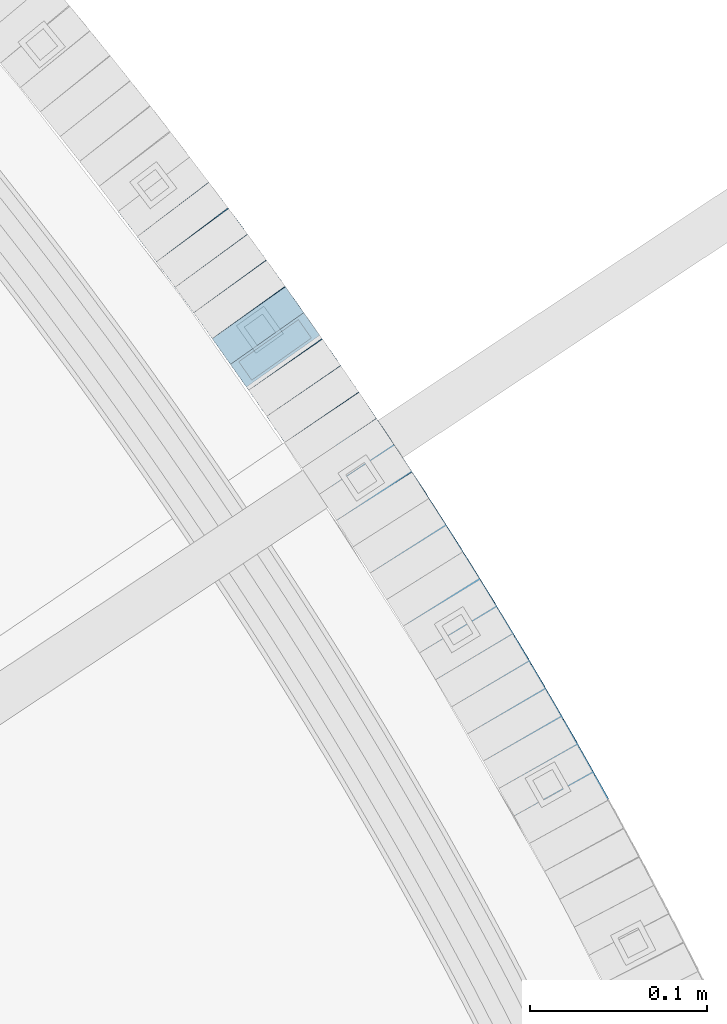
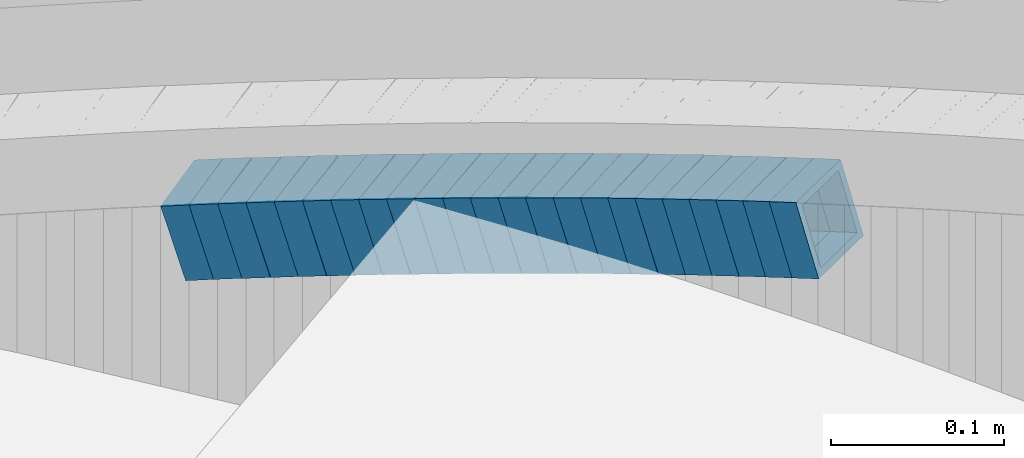
# One storey, part 808 of 975: 23 beams.
"""IFC2X3 building model written with IfcOpenShell, lengths in millimetres."""

from ifc_helpers import new_model, si_unit, frame, origin_with_axes, place, context, subcontext, project, spatial, faceted_brep, material, type_object, element, save


model = new_model("IFC2X3")

# Units and contexts
model_context = context("Model", 3, precision=1e-05, world=origin_with_axes())
body_context = subcontext(model_context, "Body", "Model", "MODEL_VIEW")
ifc_project = project(units=[si_unit("LENGTHUNIT", "METRE", prefix="MILLI"), si_unit("AREAUNIT", "SQUARE_METRE"), si_unit("VOLUMEUNIT", "CUBIC_METRE"), si_unit("MASSUNIT", "GRAM", prefix="KILO"), si_unit("TIMEUNIT", "SECOND"), si_unit("PLANEANGLEUNIT", "RADIAN"), si_unit("SOLIDANGLEUNIT", "STERADIAN"), si_unit("THERMODYNAMICTEMPERATUREUNIT", "DEGREE_CELSIUS"), si_unit("LUMINOUSINTENSITYUNIT", "LUMEN")], contexts=[model_context])

# Site, building, storey
site_placement = place(None, origin_with_axes())
site = spatial("IfcSite", under=ifc_project, at=site_placement, CompositionType="ELEMENT")
building_placement = place(site_placement, origin_with_axes())
building = spatial("IfcBuilding", under=site, at=building_placement, Name="Undefined", CompositionType="ELEMENT")
storey_placement = place(building_placement, origin_with_axes())
storey = spatial("IfcBuildingStorey", under=building, at=storey_placement, Name="Undefined", CompositionType="ELEMENT", Elevation=0.0)

# Beams
ifc_material = material()
beam_type = type_object("IfcBeamType", Name="HSS2X2X.188_TUBES", PredefinedType="NOTDEFINED")
beam_1_placement = place(storey_placement, frame((37245.682915631, 4794.72822653761, 2011.89610703231), z_axis=(-0.870978467775846, -0.491321186873556, 0.0), x_axis=(-0.468184465966171, 0.829963370939734, -0.303255846977968)))
element("IfcBeam", 1, at=beam_1_placement, inside=storey, type_object=beam_type, material=ifc_material, Name="WALL", ObjectType="HSS2X2X.188_TUBES", context=body_context, shape_type="Brep", body=[
    faceted_brep([(0.0, 20.6374999999753, -20.6375000000298), (0.0, -20.6375000000153, -20.6375000000153), (18.8047866246379, -20.6374999999916, -20.6375000000298), (18.8047866247143, 20.6374999999844, -20.6374999999643), (0.0, -20.6374999999825, 20.6375000000335), (18.8047866247107, -20.6375000000189, 20.6375000000407), (0.0, 20.6375000000116, 20.6375000000189), (18.8047866247907, 20.6374999999589, 20.6375000001026), (0.0, 25.3999999999724, -25.4000000000342), (0.0, 25.400000000016, 25.4000000000196), (18.8047866248016, 25.3999999999542, 25.4000000001142), (18.8047866247143, 25.3999999999851, -25.3999999999651), (0.0, -25.399999999976, 25.4000000000378), (18.8047866247107, -25.4000000000196, 25.4000000000415), (0.0, -25.400000000016, -25.4000000000196), (18.8047866246197, -25.3999999999887, -25.4000000000378)], [[[0, 1, 2, 3]], [[1, 4, 5, 2]], [[4, 6, 7, 5]], [[6, 0, 3, 7]], [[8, 9, 10, 11]], [[9, 12, 13, 10]], [[12, 14, 15, 13]], [[14, 8, 11, 15]], [[13, 15, 11, 10], [5, 7, 3, 2]], [[14, 12, 9, 8], [6, 4, 1, 0]]]),
])
beam_2_placement = place(storey_placement, frame((37236.8837602042, 4810.36994006417, 2006.20699476173), z_axis=(-0.869620813888914, -0.493720204216096, 7.76358319853899e-11), x_axis=(-0.470258877823187, 0.828296886688576, -0.304599499885487)))
element("IfcBeam", 2, at=beam_2_placement, inside=storey, type_object=beam_type, material=ifc_material, Name="WALL", ObjectType="HSS2X2X.188_TUBES", context=body_context, shape_type="Brep", body=[
    faceted_brep([(0.0, 20.6374999999753, -20.6375000000298), (0.0, -20.6375000000153, -20.6375000000153), (18.7112265765609, -20.6375000000062, -20.6374999999862), (18.7112265765645, 20.6374999999898, -20.6374999999789), (0.0, -20.6374999999825, 20.6375000000335), (18.7112265765209, -20.6374999999916, 20.6374999999607), (0.0, 20.6375000000116, 20.6375000000189), (18.7112265765245, 20.6375000000025, 20.6374999999716), (0.0, 25.3999999999724, -25.4000000000342), (0.0, 25.400000000016, 25.4000000000196), (18.7112265765172, 25.4000000000051, 25.3999999999614), (18.7112265765718, 25.3999999999887, -25.3999999999724), (0.0, -25.399999999976, 25.4000000000378), (18.7112265765136, -25.3999999999905, 25.3999999999542), (0.0, -25.400000000016, -25.4000000000196), (18.7112265765682, -25.4000000000069, -25.3999999999796)], [[[0, 1, 2, 3]], [[1, 4, 5, 2]], [[4, 6, 7, 5]], [[6, 0, 3, 7]], [[8, 9, 10, 11]], [[9, 12, 13, 10]], [[12, 14, 15, 13]], [[14, 8, 11, 15]], [[13, 15, 11, 10], [5, 7, 3, 2]], [[14, 12, 9, 8], [6, 4, 1, 0]]]),
])
beam_3_placement = place(storey_placement, frame((37228.0679755835, 4826.04901976158, 2000.53379788155), z_axis=(-0.864788946395478, -0.502135517756113, 3.0982323551143e-10), x_axis=(-0.477744426089833, 0.82278206615493, -0.307879741057965)))
element("IfcBeam", 3, at=beam_3_placement, inside=storey, type_object=beam_type, material=ifc_material, Name="WALL", ObjectType="HSS2X2X.188_TUBES", context=body_context, shape_type="Brep", body=[
    faceted_brep([(0.0, 20.6374999999753, -20.6375000000298), (0.0, -20.6375000000153, -20.6375000000153), (18.8433011969464, -20.6374999999898, -20.6375000000226), (18.8433011969719, 20.6375000000007, -20.6374999999862), (0.0, -20.6374999999825, 20.6375000000335), (18.8433011969828, -20.6375000000044, 20.6375000000189), (0.0, 20.6375000000116, 20.6375000000189), (18.8433011970155, 20.6374999999862, 20.6375000000517), (0.0, 25.3999999999724, -25.4000000000342), (0.0, 25.400000000016, 25.4000000000196), (18.8433011970228, 25.3999999999833, 25.4000000000597), (18.8433011969719, 25.4000000000015, -25.3999999999869), (0.0, -25.399999999976, 25.4000000000378), (18.8433011969864, -25.4000000000051, 25.4000000000196), (0.0, -25.400000000016, -25.4000000000196), (18.8433011969391, -25.3999999999869, -25.4000000000269)], [[[0, 1, 2, 3]], [[1, 4, 5, 2]], [[4, 6, 7, 5]], [[6, 0, 3, 7]], [[8, 9, 10, 11]], [[9, 12, 13, 10]], [[12, 14, 15, 13]], [[14, 8, 11, 15]], [[13, 15, 11, 10], [5, 7, 3, 2]], [[14, 12, 9, 8], [6, 4, 1, 0]]]),
])
beam_4_placement = place(storey_placement, frame((37219.0063494716, 4841.69829916659, 1994.70533664478), z_axis=(-0.863371944222782, -0.504568019130199, 0.0), x_axis=(-0.480624148905367, 0.822401320838031, -0.304395293940056)))
element("IfcBeam", 4, at=beam_4_placement, inside=storey, type_object=beam_type, material=ifc_material, Name="WALL", ObjectType="HSS2X2X.188_TUBES", context=body_context, shape_type="Brep", body=[
    faceted_brep([(0.0, 20.6374999999753, -20.6375000000298), (0.0, -20.6375000000153, -20.6375000000153), (18.7347271129966, -20.6375000000116, -20.6375000000262), (18.7347271130257, 20.6374999999989, -20.6374999999935), (0.0, -20.6374999999825, 20.6375000000335), (18.7347271129947, -20.6375000000116, 20.6374999999607), (0.0, 20.6375000000116, 20.6375000000189), (18.7347271130147, 20.6375000000007, 20.6374999999898), (0.0, 25.3999999999724, -25.4000000000342), (0.0, 25.400000000016, 25.4000000000196), (18.7347271130166, 25.4000000000015, 25.3999999999905), (18.7347271130257, 25.3999999999996, -25.3999999999869), (0.0, -25.399999999976, 25.4000000000378), (18.7347271129875, -25.4000000000106, 25.3999999999505), (0.0, -25.400000000016, -25.4000000000196), (18.7347271130002, -25.4000000000124, -25.4000000000233)], [[[0, 1, 2, 3]], [[1, 4, 5, 2]], [[4, 6, 7, 5]], [[6, 0, 3, 7]], [[8, 9, 10, 11]], [[9, 12, 13, 10]], [[12, 14, 15, 13]], [[14, 8, 11, 15]], [[13, 15, 11, 10], [5, 7, 3, 2]], [[14, 12, 9, 8], [6, 4, 1, 0]]]),
])
beam_5_placement = place(storey_placement, frame((37209.96551949, 4857.28463881204, 1989.0097921174), z_axis=(-0.859469187145032, -0.511187554962226, -3.09330062009393e-10), x_axis=(-0.486839890903448, 0.81853300483774, -0.304943667939537)))
element("IfcBeam", 5, at=beam_5_placement, inside=storey, type_object=beam_type, material=ifc_material, Name="WALL", ObjectType="HSS2X2X.188_TUBES", context=body_context, shape_type="Brep", body=[
    faceted_brep([(0.0, 20.6374999999753, -20.6375000000298), (0.0, -20.6375000000153, -20.6375000000153), (18.6895692834223, -20.637499999988, -20.6374999999862), (18.6895692834369, 20.6374999999953, -20.6374999999534), (0.0, -20.6374999999825, 20.6375000000335), (18.6895692833914, -20.637499999988, 20.6374999999789), (0.0, 20.6375000000116, 20.6375000000189), (18.6895692834078, 20.6374999999953, 20.637500000008), (0.0, 25.3999999999724, -25.4000000000342), (0.0, 25.400000000016, 25.4000000000196), (18.6895692834059, 25.3999999999924, 25.4000000000087), (18.6895692834423, 25.3999999999942, -25.3999999999432), (0.0, -25.399999999976, 25.4000000000378), (18.6895692833878, -25.3999999999869, 25.3999999999687), (0.0, -25.400000000016, -25.4000000000196), (18.6895692834241, -25.3999999999869, -25.3999999999833)], [[[0, 1, 2, 3]], [[1, 4, 5, 2]], [[4, 6, 7, 5]], [[6, 0, 3, 7]], [[8, 9, 10, 11]], [[9, 12, 13, 10]], [[12, 14, 15, 13]], [[14, 8, 11, 15]], [[13, 15, 11, 10], [5, 7, 3, 2]], [[14, 12, 9, 8], [6, 4, 1, 0]]]),
])
beam_6_placement = place(storey_placement, frame((37200.8461637376, 4872.76189874815, 1983.33619127694), z_axis=(-0.854521941415858, -0.519415297848334, -1.11954477688414e-10), x_axis=(-0.494135901994879, 0.812933257991443, -0.308170777996756)))
element("IfcBeam", 6, at=beam_6_placement, inside=storey, type_object=beam_type, material=ifc_material, Name="WALL", ObjectType="HSS2X2X.188_TUBES", context=body_context, shape_type="Brep", body=[
    faceted_brep([(0.0, 20.6374999999753, -20.6375000000298), (0.0, -20.6375000000153, -20.6375000000153), (18.8225928075335, -20.6374999999935, -20.6375000000298), (18.8225928075699, 20.6374999999898, -20.6374999999825), (0.0, -20.6374999999825, 20.6375000000335), (18.8225928075772, -20.637500000008, 20.6375000000226), (0.0, 20.6375000000116, 20.6375000000189), (18.8225928076135, 20.6374999999753, 20.6375000000698), (0.0, 25.3999999999724, -25.4000000000342), (0.0, 25.400000000016, 25.4000000000196), (18.8225928076281, 25.3999999999705, 25.4000000000815), (18.8225928075663, 25.3999999999905, -25.3999999999796), (0.0, -25.399999999976, 25.4000000000378), (18.8225928075808, -25.4000000000087, 25.4000000000233), (0.0, -25.400000000016, -25.4000000000196), (18.8225928075226, -25.3999999999905, -25.4000000000378)], [[[0, 1, 2, 3]], [[1, 4, 5, 2]], [[4, 6, 7, 5]], [[6, 0, 3, 7]], [[8, 9, 10, 11]], [[9, 12, 13, 10]], [[12, 14, 15, 13]], [[14, 8, 11, 15]], [[13, 15, 11, 10], [5, 7, 3, 2]], [[14, 12, 9, 8], [6, 4, 1, 0]]]),
])
beam_7_placement = place(storey_placement, frame((37191.4825666275, 4888.16652625196, 1977.49687076093), z_axis=(-0.854521941415858, -0.519415297848334, -1.11954477688414e-10), x_axis=(-0.494939984048736, 0.814256102080019, -0.303350313029823)))
element("IfcBeam", 7, at=beam_7_placement, inside=storey, type_object=beam_type, material=ifc_material, Name="WALL", ObjectType="HSS2X2X.188_TUBES", context=body_context, shape_type="Brep", body=[
    faceted_brep([(0.0, 20.6374999999753, -20.6375000000298), (0.0, -20.6375000000153, -20.6375000000153), (18.7853666454903, -20.6375000000535, -20.6375000000326), (18.785366645363, 20.6374999999862, -20.6375000000044), (0.0, -20.6374999999825, 20.6375000000335), (18.785366645352, -20.6375000000007, 20.6374999999989), (0.0, 20.6375000000116, 20.6375000000189), (18.7853666453102, 20.6375000000025, 20.6374999999753), (0.0, 25.3999999999724, -25.4000000000342), (0.0, 25.400000000016, 25.4000000000196), (18.7853666452065, 25.4000000000451, 25.4000000000351), (18.7853666453739, 25.3999999999833, -25.400000000006), (0.0, -25.399999999976, 25.4000000000378), (18.7853666497213, -25.399999993424, 25.3999999995158), (0.0, -25.400000000016, -25.4000000000196), (18.7853666455194, -25.4000000000633, -25.4000000000406)], [[[0, 1, 2, 3]], [[1, 4, 5, 2]], [[4, 6, 7, 5]], [[6, 0, 3, 7]], [[8, 9, 10, 11]], [[9, 12, 13, 10]], [[12, 14, 15, 13]], [[14, 8, 11, 15]], [[13, 15, 11, 10], [5, 7, 3, 2]], [[14, 12, 9, 8], [6, 4, 1, 0]]]),
])
beam_8_placement = place(storey_placement, frame((37182.0943144017, 4903.79217576543, 1971.79440949912), z_axis=(-0.847998304196438, -0.52999893969702, 2.2196581994649e-10), x_axis=(-0.5050762719802, 0.80812203596829, -0.303045762988115)))
element("IfcBeam", 8, at=beam_8_placement, inside=storey, type_object=beam_type, material=ifc_material, Name="WALL", ObjectType="HSS2X2X.188_TUBES", context=body_context, shape_type="Brep", body=[
    faceted_brep([(0.0, 20.6374999999753, -20.6375000000298), (0.0, -20.6375000000153, -20.6375000000153), (18.8066477608099, -20.6374999999862, -20.6375000000116), (18.8066477608172, 20.6375000000062, -20.6374999999971), (0.0, -20.6374999999825, 20.6375000000335), (18.8066477608463, -20.6375000000062, 20.6375000000407), (0.0, 20.6375000000116, 20.6375000000189), (18.8066477608536, 20.6374999999844, 20.637500000048), (0.0, 25.3999999999724, -25.4000000000342), (0.0, 25.400000000016, 25.4000000000196), (18.8066477608591, 25.3999999999814, 25.400000000056), (18.8066477608154, 25.4000000000051, -25.4000000000015), (0.0, -25.399999999976, 25.4000000000378), (18.8066477608518, -25.4000000000087, 25.4000000000451), (0.0, -25.400000000016, -25.4000000000196), (18.8066477608081, -25.3999999999851, -25.4000000000196)], [[[0, 1, 2, 3]], [[1, 4, 5, 2]], [[4, 6, 7, 5]], [[6, 0, 3, 7]], [[8, 9, 10, 11]], [[9, 12, 13, 10]], [[12, 14, 15, 13]], [[14, 8, 11, 15]], [[13, 15, 11, 10], [5, 7, 3, 2]], [[14, 12, 9, 8], [6, 4, 1, 0]]]),
])
beam_9_placement = place(storey_placement, frame((37172.6566376514, 4918.93626818793, 1966.14455113294), z_axis=(-0.846420002588978, -0.532515895741408, 0.0), x_axis=(-0.506423642106193, 0.804947051168941, -0.309184960064886)))
element("IfcBeam", 9, at=beam_9_placement, inside=storey, type_object=beam_type, material=ifc_material, Name="WALL", ObjectType="HSS2X2X.188_TUBES", context=body_context, shape_type="Brep", body=[
    faceted_brep([(0.0, 20.6374999999753, -20.6375000000298), (0.0, -20.6375000000153, -20.6375000000153), (18.7555325170906, -20.6374999999916, -20.6374999999971), (18.7555325171452, 20.637499999988, -20.6374999999571), (0.0, -20.6374999999825, 20.6375000000335), (18.7555325170615, -20.6374999999844, 20.6374999999716), (0.0, 20.6375000000116, 20.6375000000189), (18.7555325171015, 20.6374999999953, 20.637500000008), (0.0, 25.3999999999724, -25.4000000000342), (0.0, 25.400000000016, 25.4000000000196), (18.7555325171015, 25.399999999996, 25.4000000000051), (18.7555325171488, 25.3999999999851, -25.3999999999505), (0.0, -25.399999999976, 25.4000000000378), (18.755532517047, -25.3999999999814, 25.3999999999578), (0.0, -25.400000000016, -25.4000000000196), (18.7555325170979, -25.3999999999924, -25.3999999999978)], [[[0, 1, 2, 3]], [[1, 4, 5, 2]], [[4, 6, 7, 5]], [[6, 0, 3, 7]], [[8, 9, 10, 11]], [[9, 12, 13, 10]], [[12, 14, 15, 13]], [[14, 8, 11, 15]], [[13, 15, 11, 10], [5, 7, 3, 2]], [[14, 12, 9, 8], [6, 4, 1, 0]]]),
])
beam_10_placement = place(storey_placement, frame((37153.3639305023, 4949.46342852692, 1954.64154735545), z_axis=(-0.83972031877, -0.543019139851267, 0.0), x_axis=(-0.51647646387282, 0.798674943803473, -0.308820977924018)))
element("IfcBeam", 10, at=beam_10_placement, inside=storey, type_object=beam_type, material=ifc_material, Name="WALL", ObjectType="HSS2X2X.188_TUBES", context=body_context, shape_type="Brep", body=[
    faceted_brep([(0.0, 20.6374999999753, -20.6375000000298), (0.0, -20.6375000000153, -20.6375000000153), (18.7771137292038, -20.637500000008, -20.6374999999862), (18.777113729182, 20.6375000000062, -20.6375000000189), (0.0, -20.6374999999825, 20.6375000000335), (18.7771137291729, -20.6374999999916, 20.6374999999753), (0.0, 20.6375000000116, 20.6375000000189), (18.7771137291529, 20.6375000000207, 20.6374999999389), (0.0, 25.3999999999724, -25.4000000000342), (0.0, 25.400000000016, 25.4000000000196), (18.7771137291475, 25.4000000000251, 25.3999999999287), (18.7771137291857, 25.4000000000051, -25.4000000000196), (0.0, -25.399999999976, 25.4000000000378), (18.7771137291711, -25.3999999999905, 25.3999999999724), (0.0, -25.400000000016, -25.4000000000196), (18.7771137292129, -25.4000000000124, -25.3999999999724)], [[[0, 1, 2, 3]], [[1, 4, 5, 2]], [[4, 6, 7, 5]], [[6, 0, 3, 7]], [[8, 9, 10, 11]], [[9, 12, 13, 10]], [[12, 14, 15, 13]], [[14, 8, 11, 15]], [[13, 15, 11, 10], [5, 7, 3, 2]], [[14, 12, 9, 8], [6, 4, 1, 0]]]),
])
beam_11_placement = place(storey_placement, frame((37163.0015788307, 4934.41679448157, 1960.29161392078), z_axis=(-0.841359465256224, -0.540475947867952, -7.92667833593441e-11), x_axis=(-0.515120095331476, 0.801887983516163, -0.302699437194841)))
element("IfcBeam", 11, at=beam_11_placement, inside=storey, type_object=beam_type, material=ifc_material, Name="WALL", ObjectType="HSS2X2X.188_TUBES", context=body_context, shape_type="Brep", body=[
    faceted_brep([(0.0, 20.6374999999753, -20.6375000000298), (0.0, -20.6375000000153, -20.6375000000153), (18.8332159191086, -20.6374999999916, -20.6375000000153), (18.8332159190923, 20.6375000000062, -20.6375000000335), (0.0, -20.6374999999825, 20.6375000000335), (18.8332159191377, -20.6375000000062, 20.6375000000335), (0.0, 20.6375000000116, 20.6375000000189), (18.8332159191141, 20.6374999999916, 20.6375000000116), (0.0, 25.3999999999724, -25.4000000000342), (0.0, 25.400000000016, 25.4000000000196), (18.8332159191159, 25.3999999999905, 25.4000000000124), (18.8332159190886, 25.4000000000069, -25.4000000000415), (0.0, -25.399999999976, 25.4000000000378), (18.8332159191395, -25.4000000000069, 25.4000000000378), (0.0, -25.400000000016, -25.4000000000196), (18.8332159191104, -25.3999999999905, -25.400000000016)], [[[0, 1, 2, 3]], [[1, 4, 5, 2]], [[4, 6, 7, 5]], [[6, 0, 3, 7]], [[8, 9, 10, 11]], [[9, 12, 13, 10]], [[12, 14, 15, 13]], [[14, 8, 11, 15]], [[13, 15, 11, 10], [5, 7, 3, 2]], [[14, 12, 9, 8], [6, 4, 1, 0]]]),
])
for number, where, z_axis, x_axis, name in (
    (12, (37143.4989198919, 4964.89141179759, 1948.79881920886), (-0.832909293569711, -0.553409530714104, 0.0), (-0.527289925906025, 0.793597968858369, -0.303591168945821), "WALL"),
    (13, (37133.5989198919, 4979.79141179758, 1943.09881920879), (-0.832909293569711, -0.553409530714104, 0.0), (-0.527289925906025, 0.793597968858369, -0.303591168945821), "WALL"),
):
    element("IfcBeam", number, at=place(storey_placement, frame(where, z_axis=z_axis, x_axis=x_axis)), inside=storey, type_object=beam_type, material=ifc_material, Name=name, ObjectType="HSS2X2X.188_TUBES", context=body_context, shape_type="Brep", body=[
        faceted_brep([(0.0, 20.6374999999753, -20.6375000000298), (0.0, -20.6375000000153, -20.6375000000153), (18.7771137292038, -20.637500000008, -20.6374999999862), (18.777113729182, 20.6375000000062, -20.6375000000189), (0.0, -20.6374999999825, 20.6375000000335), (18.7771137291729, -20.6374999999916, 20.6374999999753), (0.0, 20.6375000000116, 20.6375000000189), (18.7771137291529, 20.6375000000207, 20.6374999999389), (0.0, 25.3999999999724, -25.4000000000342), (0.0, 25.400000000016, 25.4000000000196), (18.7771137291475, 25.4000000000251, 25.3999999999287), (18.7771137291857, 25.4000000000051, -25.4000000000196), (0.0, -25.399999999976, 25.4000000000378), (18.7771137291711, -25.3999999999905, 25.3999999999724), (0.0, -25.400000000016, -25.4000000000196), (18.7771137292129, -25.4000000000124, -25.3999999999724)], [[[0, 1, 2, 3]], [[1, 4, 5, 2]], [[4, 6, 7, 5]], [[6, 0, 3, 7]], [[8, 9, 10, 11]], [[9, 12, 13, 10]], [[12, 14, 15, 13]], [[14, 8, 11, 15]], [[13, 15, 11, 10], [5, 7, 3, 2]], [[14, 12, 9, 8], [6, 4, 1, 0]]]),
    ])
beam_12_placement = place(storey_placement, frame((37113.5650646805, 5009.81391287097, 1931.63451135568), z_axis=(-0.825991119591446, -0.563683129387487, 1.78150003193877e-10), x_axis=(-0.536286546161319, 0.785845631236281, -0.307966531092608)))
element("IfcBeam", 14, at=beam_12_placement, inside=storey, type_object=beam_type, material=ifc_material, Name="WALL", ObjectType="HSS2X2X.188_TUBES", context=body_context, shape_type="Brep", body=[
    faceted_brep([(0.0, 20.6374999999753, -20.6375000000298), (0.0, -20.6375000000153, -20.6375000000153), (18.8332159191086, -20.6374999999916, -20.6375000000153), (18.8332159190923, 20.6375000000062, -20.6375000000335), (0.0, -20.6374999999825, 20.6375000000335), (18.8332159191377, -20.6375000000062, 20.6375000000335), (0.0, 20.6375000000116, 20.6375000000189), (18.8332159191141, 20.6374999999916, 20.6375000000116), (0.0, 25.3999999999724, -25.4000000000342), (0.0, 25.400000000016, 25.4000000000196), (18.8332159191159, 25.3999999999905, 25.4000000000124), (18.8332159190886, 25.4000000000069, -25.4000000000415), (0.0, -25.399999999976, 25.4000000000378), (18.8332159191395, -25.4000000000069, 25.4000000000378), (0.0, -25.400000000016, -25.4000000000196), (18.8332159191104, -25.3999999999905, -25.400000000016)], [[[0, 1, 2, 3]], [[1, 4, 5, 2]], [[4, 6, 7, 5]], [[6, 0, 3, 7]], [[8, 9, 10, 11]], [[9, 12, 13, 10]], [[12, 14, 15, 13]], [[14, 8, 11, 15]], [[13, 15, 11, 10], [5, 7, 3, 2]], [[14, 12, 9, 8], [6, 4, 1, 0]]]),
])
beam_13_placement = place(storey_placement, frame((37123.6712802815, 4994.861309302, 1937.42400035625), z_axis=(-0.827752200953588, -0.561093836908312, -1.60625859280116e-11), x_axis=(-0.53405529174789, 0.787863658627905, -0.306685181855153)))
element("IfcBeam", 15, at=beam_13_placement, inside=storey, type_object=beam_type, material=ifc_material, Name="WALL", ObjectType="HSS2X2X.188_TUBES", context=body_context, shape_type="Brep", body=[
    faceted_brep([(0.0, 20.6374999999753, -20.6375000000298), (0.0, -20.6375000000153, -20.6375000000153), (18.9092569923087, -20.6374999999971, -20.6374999999971), (18.9092569922723, 20.6375000000107, -20.6374999999098), (0.0, -20.6374999999825, 20.6375000000335), (18.9092569923087, -20.6374999999998, 20.6375000000044), (0.0, 20.6375000000116, 20.6375000000189), (18.9092569922686, 20.637500000008, 20.6375000001062), (0.0, 25.3999999999724, -25.4000000000342), (0.0, 25.400000000016, 25.4000000000196), (18.909256992265, 25.4000000000078, 25.4000000001106), (18.909256992265, 25.4000000000133, -25.3999999998996), (0.0, -25.399999999976, 25.4000000000378), (18.9092569923123, -25.4000000000024, 25.3999999999869), (0.0, -25.400000000016, -25.4000000000196), (18.9092569923123, -25.3999999999987, -25.400000000016)], [[[0, 1, 2, 3]], [[1, 4, 5, 2]], [[4, 6, 7, 5]], [[6, 0, 3, 7]], [[8, 9, 10, 11]], [[9, 12, 13, 10]], [[12, 14, 15, 13]], [[14, 8, 11, 15]], [[13, 15, 11, 10], [5, 7, 3, 2]], [[14, 12, 9, 8], [6, 4, 1, 0]]]),
])
beam_14_placement = place(storey_placement, frame((37103.3467580943, 5024.84939103153, 1925.78824907115), z_axis=(-0.823392066704671, -0.567472910796463, 0.0), x_axis=(-0.540925699845876, 0.784872584776205, -0.30228200891381)))
element("IfcBeam", 16, at=beam_14_placement, inside=storey, type_object=beam_type, material=ifc_material, Name="WALL", ObjectType="HSS2X2X.188_TUBES", context=body_context, shape_type="Brep", body=[
    faceted_brep([(0.0, 20.6374999999753, -20.6375000000298), (0.0, -20.6375000000153, -20.6375000000153), (18.8565638439322, -20.6375000000116, -20.6374999999643), (18.8565638439395, 20.637499999988, -20.6374999999534), (0.0, -20.6374999999825, 20.6375000000335), (18.856563843914, -20.6374999999953, 20.6375000000116), (0.0, 20.6375000000116, 20.6375000000189), (18.8565638439177, 20.6375000000007, 20.6375000000226), (0.0, 25.3999999999724, -25.4000000000342), (0.0, 25.400000000016, 25.4000000000196), (18.8565638439177, 25.4000000000033, 25.4000000000233), (18.8565638439468, 25.3999999999851, -25.3999999999505), (0.0, -25.399999999976, 25.4000000000378), (18.8565638439104, -25.399999999996, 25.4000000000087), (0.0, -25.400000000016, -25.4000000000196), (18.8565638439395, -25.4000000000124, -25.3999999999614)], [[[0, 1, 2, 3]], [[1, 4, 5, 2]], [[4, 6, 7, 5]], [[6, 0, 3, 7]], [[8, 9, 10, 11]], [[9, 12, 13, 10]], [[12, 14, 15, 13]], [[14, 8, 11, 15]], [[13, 15, 11, 10], [5, 7, 3, 2]], [[14, 12, 9, 8], [6, 4, 1, 0]]]),
])
beam_15_placement = place(storey_placement, frame((37093.0805831007, 5039.89182011327, 1920.10150871287), z_axis=(-0.817122939119161, -0.576463444084067, 0.0), x_axis=(-0.549194709889712, 0.778470170843582, -0.303923285938934)))
element("IfcBeam", 17, at=beam_15_placement, inside=storey, type_object=beam_type, material=ifc_material, Name="WALL", ObjectType="HSS2X2X.188_TUBES", context=body_context, shape_type="Brep", body=[
    faceted_brep([(0.0, 20.6374999999753, -20.6375000000298), (0.0, -20.6375000000153, -20.6375000000153), (18.7547327359644, -20.6374999999844, -20.6375000000553), (18.7547327359898, 20.6375000000171, -20.6375000000335), (0.0, -20.6374999999825, 20.6375000000335), (18.7547327360044, -20.6374999999953, 20.6374999999898), (0.0, 20.6375000000116, 20.6375000000189), (18.7547327360262, 20.6375000000062, 20.6375000000116), (0.0, 25.3999999999724, -25.4000000000342), (0.0, 25.400000000016, 25.4000000000196), (18.7547327360371, 25.4000000000033, 25.4000000000124), (18.7547327359898, 25.4000000000178, -25.4000000000342), (0.0, -25.399999999976, 25.4000000000378), (18.7547327360044, -25.399999999996, 25.3999999999869), (0.0, -25.400000000016, -25.4000000000196), (18.7547327359498, -25.3999999999814, -25.4000000000597)], [[[0, 1, 2, 3]], [[1, 4, 5, 2]], [[4, 6, 7, 5]], [[6, 0, 3, 7]], [[8, 9, 10, 11]], [[9, 12, 13, 10]], [[12, 14, 15, 13]], [[14, 8, 11, 15]], [[13, 15, 11, 10], [5, 7, 3, 2]], [[14, 12, 9, 8], [6, 4, 1, 0]]]),
])
beam_16_placement = place(storey_placement, frame((37082.8512707432, 5054.39162209567, 1914.44096998083), z_axis=(-0.817122939119161, -0.576463444084067, 0.0), x_axis=(-0.548299120091738, 0.777200694130088, -0.308750961051679)))
element("IfcBeam", 18, at=beam_16_placement, inside=storey, type_object=beam_type, material=ifc_material, Name="WALL", ObjectType="HSS2X2X.188_TUBES", context=body_context, shape_type="Brep", body=[
    faceted_brep([(0.0, 20.6374999999753, -20.6375000000298), (0.0, -20.6375000000153, -20.6375000000153), (18.7853666454903, -20.6375000000535, -20.6375000000326), (18.785366645363, 20.6374999999862, -20.6375000000044), (0.0, -20.6374999999825, 20.6375000000335), (18.785366645352, -20.6375000000007, 20.6374999999989), (0.0, 20.6375000000116, 20.6375000000189), (18.7853666453102, 20.6375000000025, 20.6374999999753), (0.0, 25.3999999999724, -25.4000000000342), (0.0, 25.400000000016, 25.4000000000196), (18.7853666452065, 25.4000000000451, 25.4000000000351), (18.7853666453739, 25.3999999999833, -25.400000000006), (0.0, -25.399999999976, 25.4000000000378), (18.7853666497213, -25.399999993424, 25.3999999995158), (0.0, -25.400000000016, -25.4000000000196), (18.7853666455194, -25.4000000000633, -25.4000000000406)], [[[0, 1, 2, 3]], [[1, 4, 5, 2]], [[4, 6, 7, 5]], [[6, 0, 3, 7]], [[8, 9, 10, 11]], [[9, 12, 13, 10]], [[12, 14, 15, 13]], [[14, 8, 11, 15]], [[13, 15, 11, 10], [5, 7, 3, 2]], [[14, 12, 9, 8], [6, 4, 1, 0]]]),
])
beam_17_placement = place(storey_placement, frame((37072.3773861104, 5069.35725993989, 1908.58712028482), z_axis=(-0.811850633169297, -0.583865180861654, -6.69283508614169e-11), x_axis=(-0.55657706314721, 0.77390715520482, -0.302141834079972)))
element("IfcBeam", 19, at=beam_17_placement, inside=storey, type_object=beam_type, material=ifc_material, Name="WALL", ObjectType="HSS2X2X.188_TUBES", context=body_context, shape_type="Brep", body=[
    faceted_brep([(0.0, 20.6374999999753, -20.6375000000298), (0.0, -20.6375000000153, -20.6375000000153), (18.8653120832787, -20.6374999999989, -20.6374999999935), (18.8653120832823, 20.6374999999971, -20.6374999999935), (0.0, -20.6374999999825, 20.6375000000335), (18.8653120833151, -20.6375000000116, 20.6375000000298), (0.0, 20.6375000000116, 20.6375000000189), (18.8653120833151, 20.6374999999844, 20.6375000000298), (0.0, 25.3999999999724, -25.4000000000342), (0.0, 25.400000000016, 25.4000000000196), (18.8653120833187, 25.3999999999814, 25.4000000000378), (18.8653120832823, 25.3999999999942, -25.3999999999905), (0.0, -25.399999999976, 25.4000000000378), (18.8653120833187, -25.4000000000124, 25.4000000000342), (0.0, -25.400000000016, -25.4000000000196), (18.8653120832787, -25.3999999999978, -25.3999999999942)], [[[0, 1, 2, 3]], [[1, 4, 5, 2]], [[4, 6, 7, 5]], [[6, 0, 3, 7]], [[8, 9, 10, 11]], [[9, 12, 13, 10]], [[12, 14, 15, 13]], [[14, 8, 11, 15]], [[13, 15, 11, 10], [5, 7, 3, 2]], [[14, 12, 9, 8], [6, 4, 1, 0]]]),
])
beam_18_placement = place(storey_placement, frame((37061.9301785387, 5083.97113323932, 1902.94691366209), z_axis=(-0.808007530355228, -0.589172157259018, 0.0), x_axis=(-0.56024905492514, 0.76834156089707, -0.30947090695854)))
element("IfcBeam", 20, at=beam_18_placement, inside=storey, type_object=beam_type, material=ifc_material, Name="WALL", ObjectType="HSS2X2X.188_TUBES", context=body_context, shape_type="Brep", body=[
    faceted_brep([(0.0, 20.6374999999753, -20.6375000000298), (0.0, -20.6375000000153, -20.6375000000153), (18.7416648140024, -20.6375000000153, -20.6374999999825), (18.7416648139188, 20.6375000000189, -20.6375000000298), (0.0, -20.6374999999825, 20.6375000000335), (18.7416648140097, -20.6375000000189, 20.6375000000226), (0.0, 20.6375000000116, 20.6375000000189), (18.741664813926, 20.6375000000153, 20.6374999999753), (0.0, 25.3999999999724, -25.4000000000342), (0.0, 25.400000000016, 25.4000000000196), (18.7416648139224, 25.4000000000196, 25.3999999999687), (18.7416648139042, 25.4000000000233, -25.4000000000378), (0.0, -25.399999999976, 25.4000000000378), (18.7416648140133, -25.4000000000215, 25.4000000000269), (0.0, -25.400000000016, -25.4000000000196), (18.7416648140133, -25.4000000000196, -25.399999999976)], [[[0, 1, 2, 3]], [[1, 4, 5, 2]], [[4, 6, 7, 5]], [[6, 0, 3, 7]], [[8, 9, 10, 11]], [[9, 12, 13, 10]], [[12, 14, 15, 13]], [[14, 8, 11, 15]], [[13, 15, 11, 10], [5, 7, 3, 2]], [[14, 12, 9, 8], [6, 4, 1, 0]]]),
])
beam_19_placement = place(storey_placement, frame((37051.3044099248, 5098.60234497967, 1897.09986563329), z_axis=(-0.805336884132331, -0.592817428097411, 0.0), x_axis=(-0.564813441940984, 0.767293732919815, -0.303720435968266)))
element("IfcBeam", 21, at=beam_19_placement, inside=storey, type_object=beam_type, material=ifc_material, Name="WALL", ObjectType="HSS2X2X.188_TUBES", context=body_context, shape_type="Brep", body=[
    faceted_brep([(0.0, 20.6374999999753, -20.6375000000298), (0.0, -20.6375000000153, -20.6375000000153), (18.767258723612, -20.6375000000025, -20.6374999999862), (18.7672587236229, 20.6374999999953, -20.637499999968), (0.0, -20.6374999999825, 20.6375000000335), (18.767258723612, -20.6375000000135, 20.6375000000153), (0.0, 20.6375000000116, 20.6375000000189), (18.7672587236266, 20.6374999999844, 20.6375000000371), (0.0, 25.3999999999724, -25.4000000000342), (0.0, 25.400000000016, 25.4000000000196), (18.7672587236302, 25.3999999999814, 25.4000000000342), (18.7672587236229, 25.399999999996, -25.3999999999687), (0.0, -25.399999999976, 25.4000000000378), (18.7672587236157, -25.4000000000142, 25.400000000016), (0.0, -25.400000000016, -25.4000000000196), (18.767258723612, -25.4000000000015, -25.3999999999905)], [[[0, 1, 2, 3]], [[1, 4, 5, 2]], [[4, 6, 7, 5]], [[6, 0, 3, 7]], [[8, 9, 10, 11]], [[9, 12, 13, 10]], [[12, 14, 15, 13]], [[14, 8, 11, 15]], [[13, 15, 11, 10], [5, 7, 3, 2]], [[14, 12, 9, 8], [6, 4, 1, 0]]]),
])
beam_20_placement = place(storey_placement, frame((37040.5844819123, 5113.32172137381, 1891.39496326426), z_axis=(-0.79798659876433, -0.602675192946032, 3.14792032440892e-11), x_axis=(-0.574321858048396, 0.760444683064216, -0.303114314025588)))
element("IfcBeam", 22, at=beam_20_placement, inside=storey, type_object=beam_type, material=ifc_material, Name="WALL", ObjectType="HSS2X2X.188_TUBES", context=body_context, shape_type="Brep", body=[
    faceted_brep([(0.0, 20.6374999999753, -20.6375000000298), (0.0, -20.6375000000153, -20.6375000000153), (18.8047866246379, -20.6374999999916, -20.6375000000298), (18.8047866247143, 20.6374999999844, -20.6374999999643), (0.0, -20.6374999999825, 20.6375000000335), (18.8047866247107, -20.6375000000189, 20.6375000000407), (0.0, 20.6375000000116, 20.6375000000189), (18.8047866247907, 20.6374999999589, 20.6375000001026), (0.0, 25.3999999999724, -25.4000000000342), (0.0, 25.400000000016, 25.4000000000196), (18.8047866248016, 25.3999999999542, 25.4000000001142), (18.8047866247143, 25.3999999999851, -25.3999999999651), (0.0, -25.399999999976, 25.4000000000378), (18.8047866247107, -25.4000000000196, 25.4000000000415), (0.0, -25.400000000016, -25.4000000000196), (18.8047866246197, -25.3999999999887, -25.4000000000378)], [[[0, 1, 2, 3]], [[1, 4, 5, 2]], [[4, 6, 7, 5]], [[6, 0, 3, 7]], [[8, 9, 10, 11]], [[9, 12, 13, 10]], [[12, 14, 15, 13]], [[14, 8, 11, 15]], [[13, 15, 11, 10], [5, 7, 3, 2]], [[14, 12, 9, 8], [6, 4, 1, 0]]]),
])
beam_21_placement = place(storey_placement, frame((37029.8465910544, 5127.58326227095, 1885.74447858086), z_axis=(-0.795946119280133, -0.605367471213061, 0.0), x_axis=(-0.575707359048466, 0.756948565063747, -0.309176174026032)))
element("IfcBeam", 23, at=beam_21_placement, inside=storey, type_object=beam_type, material=ifc_material, Name="WALL", ObjectType="HSS2X2X.188_TUBES", context=body_context, shape_type="Brep", body=[
    faceted_brep([(0.0, 20.6374999999753, -20.6375000000298), (0.0, -20.6375000000153, -20.6375000000153), (18.7555325170906, -20.6374999999916, -20.6374999999971), (18.7555325171452, 20.637499999988, -20.6374999999571), (0.0, -20.6374999999825, 20.6375000000335), (18.7555325170615, -20.6374999999844, 20.6374999999716), (0.0, 20.6375000000116, 20.6375000000189), (18.7555325171015, 20.6374999999953, 20.637500000008), (0.0, 25.3999999999724, -25.4000000000342), (0.0, 25.400000000016, 25.4000000000196), (18.7555325171015, 25.399999999996, 25.4000000000051), (18.7555325171488, 25.3999999999851, -25.3999999999505), (0.0, -25.399999999976, 25.4000000000378), (18.755532517047, -25.3999999999814, 25.3999999999578), (0.0, -25.400000000016, -25.4000000000196), (18.7555325170979, -25.3999999999924, -25.3999999999978)], [[[0, 1, 2, 3]], [[1, 4, 5, 2]], [[4, 6, 7, 5]], [[6, 0, 3, 7]], [[8, 9, 10, 11]], [[9, 12, 13, 10]], [[12, 14, 15, 13]], [[14, 8, 11, 15]], [[13, 15, 11, 10], [5, 7, 3, 2]], [[14, 12, 9, 8], [6, 4, 1, 0]]]),
])

save(model, "model.ifc")
